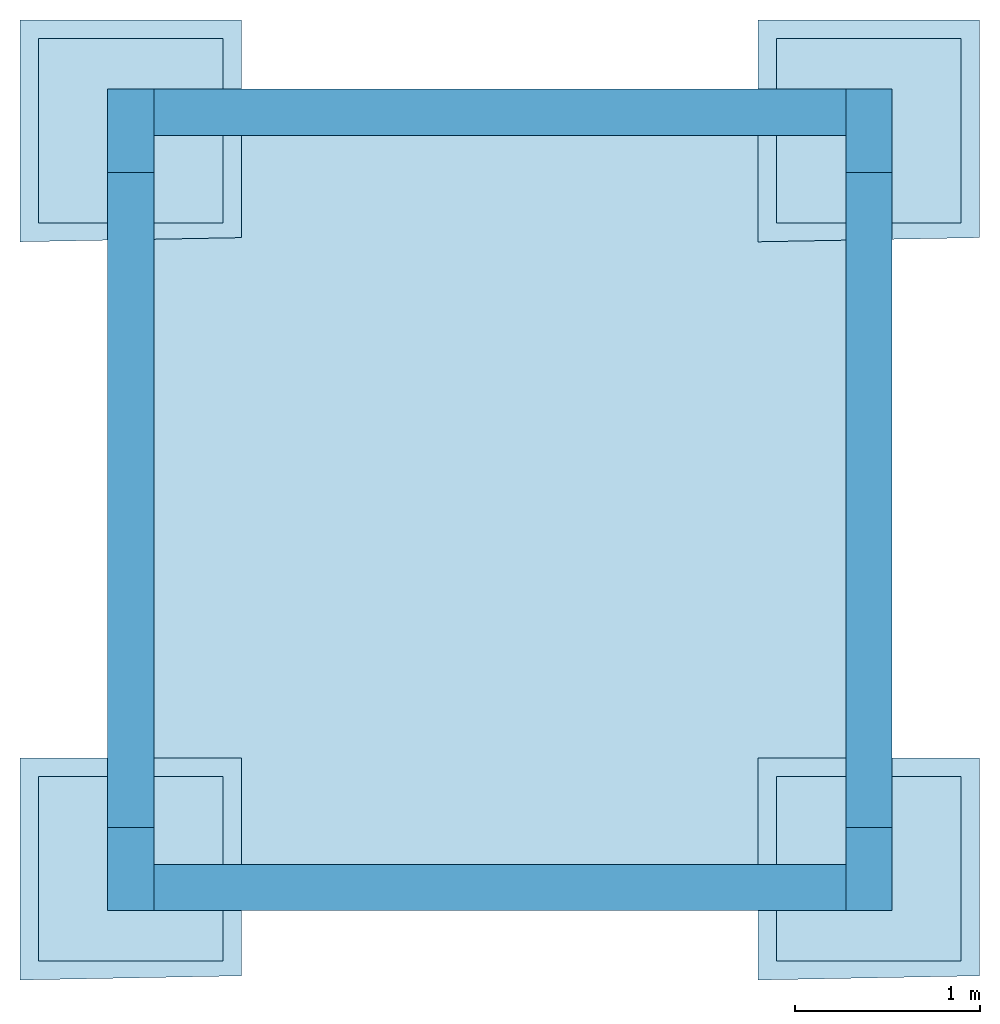
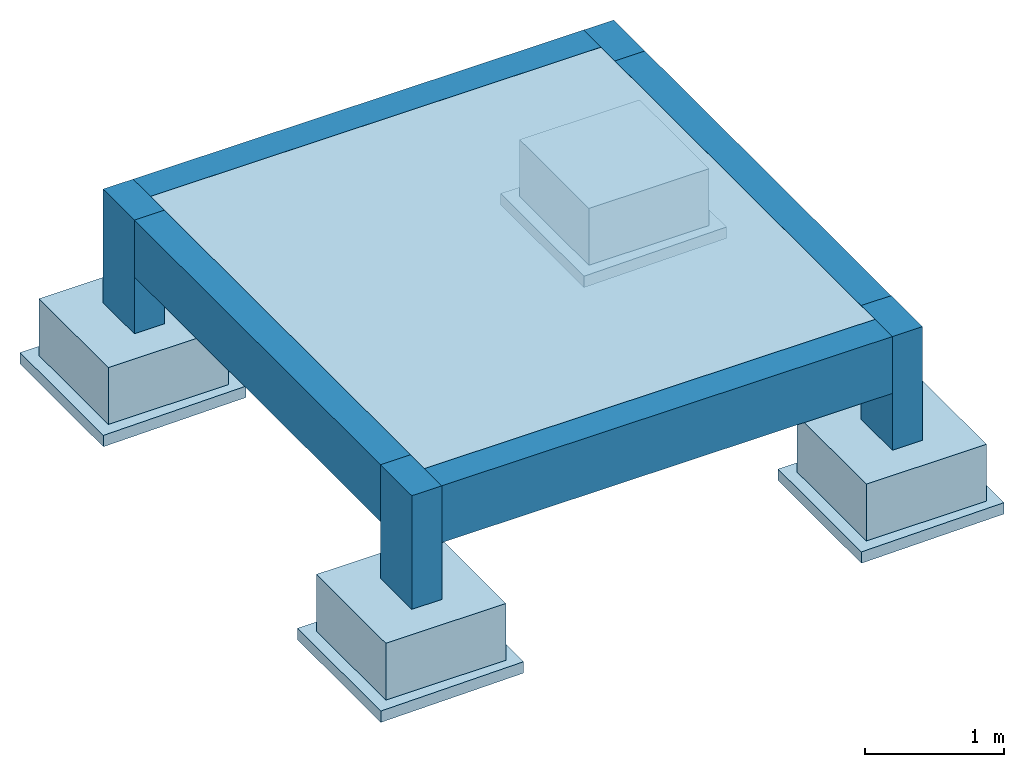
# One storey: 5 slabs, 4 beams, 4 columns, 4 footings.
"""IFC4X3_ADD2 building model written with IfcOpenShell, lengths in metres."""

from ifc_helpers import new_model, entity, si_unit, converted_unit, frame, origin_with_axes, origin_2d_with_axis, place, context, subcontext, project, spatial, indexed_curve, rectangle, outline, extrude, material, layer, layer_set, layer_usage, material_profile, profile_set, profile_usage, type_object, element, save


model = new_model("IFC4X3_ADD2")

# Units and contexts
model_context = context("Model", 3, precision=1e-05, world=origin_with_axes())
plan_context = context("Plan", 2, precision=1e-05, world=origin_2d_with_axis())
body_context = subcontext(model_context, "Body", "Model", "MODEL_VIEW")
ifc_project = project(units=[si_unit("VOLUMEUNIT", "CUBIC_METRE"), si_unit("LENGTHUNIT", "METRE"), converted_unit("PLANEANGLEUNIT", "degree", entity("IfcReal", 0.0174532925199433), si_unit("PLANEANGLEUNIT", "RADIAN"), dimensions=[0, 0, 0, 0, 0, 0, 0]), si_unit("AREAUNIT", "SQUARE_METRE")], contexts=[model_context, plan_context])

# Site, building, storey
site_placement = place(None, origin_with_axes())
site = spatial("IfcSite", under=ifc_project, at=site_placement)
building_placement = place(site_placement, origin_with_axes())
building = spatial("IfcBuilding", under=site, at=building_placement, Name="Building")
storey_placement = place(building_placement, frame((0.0, 0.0, -1.0), z_axis=(0.0, 0.0, 1.0), x_axis=(1.0, 0.0, 0.0)))
storey = spatial("IfcBuildingStorey", under=building, at=storey_placement, Name="F1")

# Footings
ifc_material_1 = material(Name="C25/30", Category="concrete")
ifc_layer_1 = layer(ifc_material_1, 0.5)
ifc_layer_set_1 = layer_set([ifc_layer_1])
ifc_layer_usage_1 = layer_usage(ifc_layer_set_1, "AXIS3", "POSITIVE", -0.5)
footing_type = type_object("IfcFootingType", Name="PAD-500", PredefinedType="PAD_FOOTING", material=ifc_layer_set_1)
footing_1_placement = place(storey_placement, origin_with_axes())
element("IfcFooting", 1, at=footing_1_placement, inside=storey, type_object=footing_type, material=ifc_layer_usage_1, Name="PAD-500", context=body_context, shape_type="SweptSolid", body=[
    extrude(outline(indexed_curve([(0.0, 0.0), (7.54979012640433e-08, 1.0), (1.00000011920929, 0.999999940395355), (1.0, -5.96046447753906e-08), (0.0, 0.0)])), frame((0.0, 0.0, -0.5), z_axis=(0.0, 0.0, 1.0), x_axis=(1.0, 0.0, 0.0)), (0.0, 0.0, 1.0), 0.5),
])
ifc_layer_usage_2 = layer_usage(ifc_layer_set_1, "AXIS3", "POSITIVE", -0.5)
footing_2_placement = place(storey_placement, frame((0.0, 4.0, 0.0), z_axis=(0.0, 0.0, 1.0), x_axis=(1.0, 0.0, 0.0)))
element("IfcFooting", 2, at=footing_2_placement, inside=storey, type_object=footing_type, material=ifc_layer_usage_2, Name="PAD-500", context=body_context, shape_type="SweptSolid", body=[
    extrude(outline(indexed_curve([(0.0, 0.0), (7.54979012640433e-08, 1.0), (1.00000011920929, 0.999999940395355), (1.0, -5.96046447753906e-08), (0.0, 0.0)])), frame((0.0, 0.0, -0.5), z_axis=(0.0, 0.0, 1.0), x_axis=(1.0, 0.0, 0.0)), (0.0, 0.0, 1.0), 0.5),
])
ifc_layer_usage_3 = layer_usage(ifc_layer_set_1, "AXIS3", "POSITIVE", -0.5)
footing_3_placement = place(storey_placement, frame((4.0, 0.0, 0.0), z_axis=(0.0, 0.0, 1.0), x_axis=(1.0, 0.0, 0.0)))
element("IfcFooting", 3, at=footing_3_placement, inside=storey, type_object=footing_type, material=ifc_layer_usage_3, Name="PAD-500", context=body_context, shape_type="SweptSolid", body=[
    extrude(outline(indexed_curve([(0.0, 0.0), (7.54979012640433e-08, 1.0), (1.00000011920929, 0.999999940395355), (1.0, -5.96046447753906e-08), (0.0, 0.0)])), frame((0.0, 0.0, -0.5), z_axis=(0.0, 0.0, 1.0), x_axis=(1.0, 0.0, 0.0)), (0.0, 0.0, 1.0), 0.5),
])
ifc_layer_usage_4 = layer_usage(ifc_layer_set_1, "AXIS3", "POSITIVE", -0.5)
footing_4_placement = place(storey_placement, frame((4.0, 4.0, 0.0), z_axis=(0.0, 0.0, 1.0), x_axis=(1.0, 0.0, 0.0)))
element("IfcFooting", 4, at=footing_4_placement, inside=storey, type_object=footing_type, material=ifc_layer_usage_4, Name="PAD-500", context=body_context, shape_type="SweptSolid", body=[
    extrude(outline(indexed_curve([(0.0, 0.0), (7.54979012640433e-08, 1.0), (1.00000011920929, 0.999999940395355), (1.0, -5.96046447753906e-08), (0.0, 0.0)])), frame((0.0, 0.0, -0.5), z_axis=(0.0, 0.0, 1.0), x_axis=(1.0, 0.0, 0.0)), (0.0, 0.0, 1.0), 0.5),
])

# Columns
ifc_material_2 = material(Name="C30/37", Category="concrete")
ifc_material_profile_1 = material_profile(ifc_material_2, rectangle(XDim=0.25, YDim=0.449999988079071))
ifc_profile_set_1 = profile_set([ifc_material_profile_1])
ifc_profile_usage_1 = profile_usage(ifc_profile_set_1, cardinal=2)
column_type = type_object("IfcColumnType", Name="COL-250x450", PredefinedType="COLUMN", material=ifc_profile_set_1)
column_1_placement = place(storey_placement, frame((0.5, 0.27499994635582, 0.0), z_axis=(0.0, 0.0, 1.0), x_axis=(1.0, 0.0, 0.0)))
element("IfcColumn", 5, at=column_1_placement, inside=storey, type_object=column_type, material=ifc_profile_usage_1, Name="COL-250x450", context=body_context, shape_type="SweptSolid", body=[
    extrude(rectangle(XDim=0.25, YDim=0.449999988079071), frame((0.0, 0.224999994039536, 0.0), z_axis=(0.0, 0.0, 1.0), x_axis=(1.0, 0.0, 0.0)), (0.0, 0.0, 1.0), 1.0),
])
ifc_profile_usage_2 = profile_usage(ifc_profile_set_1, cardinal=2)
column_2_placement = place(storey_placement, frame((0.5, 4.27500009536743, 0.0), z_axis=(0.0, 0.0, 1.0), x_axis=(1.0, 0.0, 0.0)))
element("IfcColumn", 6, at=column_2_placement, inside=storey, type_object=column_type, material=ifc_profile_usage_2, Name="COL-250x450", context=body_context, shape_type="SweptSolid", body=[
    extrude(rectangle(XDim=0.25, YDim=0.449999988079071), frame((0.0, 0.224999994039536, 0.0), z_axis=(0.0, 0.0, 1.0), x_axis=(1.0, 0.0, 0.0)), (0.0, 0.0, 1.0), 1.0),
])
ifc_profile_usage_3 = profile_usage(ifc_profile_set_1, cardinal=2)
column_3_placement = place(storey_placement, frame((4.5, 0.27499994635582, 0.0), z_axis=(0.0, 0.0, 1.0), x_axis=(1.0, 0.0, 0.0)))
element("IfcColumn", 7, at=column_3_placement, inside=storey, type_object=column_type, material=ifc_profile_usage_3, Name="COL-250x450", context=body_context, shape_type="SweptSolid", body=[
    extrude(rectangle(XDim=0.25, YDim=0.449999988079071), frame((0.0, 0.224999994039536, 0.0), z_axis=(0.0, 0.0, 1.0), x_axis=(1.0, 0.0, 0.0)), (0.0, 0.0, 1.0), 1.0),
])
ifc_profile_usage_4 = profile_usage(ifc_profile_set_1, cardinal=2)
column_4_placement = place(storey_placement, frame((4.5, 4.27500009536743, 0.0), z_axis=(0.0, 0.0, 1.0), x_axis=(1.0, 0.0, 0.0)))
element("IfcColumn", 8, at=column_4_placement, inside=storey, type_object=column_type, material=ifc_profile_usage_4, Name="COL-250x450", context=body_context, shape_type="SweptSolid", body=[
    extrude(rectangle(XDim=0.25, YDim=0.449999988079071), frame((0.0, 0.224999994039536, 0.0), z_axis=(0.0, 0.0, 1.0), x_axis=(1.0, 0.0, 0.0)), (0.0, 0.0, 1.0), 1.0),
])

# Beams
ifc_material_3 = material()
ifc_material_profile_2 = material_profile(ifc_material_3, rectangle(XDim=0.25, YDim=0.5))
ifc_profile_set_2 = profile_set([ifc_material_profile_2])
ifc_profile_usage_5 = profile_usage(ifc_profile_set_2, cardinal=8)
beam_type = type_object("IfcBeamType", Name="BEM-250x500", PredefinedType="BEAM", material=ifc_profile_set_2)
beam_1_placement = place(storey_placement, frame((0.500000178813934, 0.724999904632568, 1.0), z_axis=(-8.74227765734753e-08, 0.999999999999993, 7.54979012640428e-08), x_axis=(-0.999999999999992, -8.74227765734752e-08, 8.74227836789026e-08)))
element("IfcBeam", 9, at=beam_1_placement, inside=storey, type_object=beam_type, material=ifc_profile_usage_5, Name="250x500", context=body_context, shape_type="SweptSolid", body=[
    extrude(rectangle(XDim=0.25, YDim=0.5), frame((0.0, -0.25, 0.0), z_axis=(0.0, 0.0, 1.0), x_axis=(1.0, 0.0, 0.0)), (0.0, 0.0, 1.0), 3.55000012894753),
])
ifc_profile_usage_6 = profile_usage(ifc_profile_set_2, cardinal=8)
beam_2_placement = place(storey_placement, frame((4.5, 0.724999904632568, 1.0), z_axis=(-8.74227765734753e-08, 0.999999999999993, 7.54979012640428e-08), x_axis=(-0.999999999999992, -8.74227765734752e-08, 8.74227836789026e-08)))
element("IfcBeam", 10, at=beam_2_placement, inside=storey, type_object=beam_type, material=ifc_profile_usage_6, Name="250x500", context=body_context, shape_type="SweptSolid", body=[
    extrude(rectangle(XDim=0.25, YDim=0.5), frame((0.0, -0.25, 0.0), z_axis=(0.0, 0.0, 1.0), x_axis=(1.0, 0.0, 0.0)), (0.0, 0.0, 1.0), 3.55000012894753),
])
ifc_profile_usage_7 = profile_usage(ifc_profile_set_2, cardinal=8)
beam_3_placement = place(storey_placement, frame((4.375, 4.59999990463257, 1.0), z_axis=(-0.999999999999997, -1.19248735330757e-08, 7.54979012640431e-08), x_axis=(1.1924880638503e-08, -0.999999999999996, 8.74227765734755e-08)))
element("IfcBeam", 11, at=beam_3_placement, inside=storey, type_object=beam_type, material=ifc_profile_usage_7, Name="250x500", context=body_context, shape_type="SweptSolid", body=[
    extrude(rectangle(XDim=0.25, YDim=0.5), frame((0.0, -0.25, 0.0), z_axis=(0.0, 0.0, 1.0), x_axis=(1.0, 0.0, 0.0)), (0.0, 0.0, 1.0), 3.75000025431315),
])
ifc_profile_usage_8 = profile_usage(ifc_profile_set_2, cardinal=8)
beam_4_placement = place(storey_placement, frame((4.375, 0.400000095367432, 1.0), z_axis=(-0.999999999999997, -1.19248735330757e-08, 7.54979012640431e-08), x_axis=(1.1924880638503e-08, -0.999999999999996, 8.74227765734755e-08)))
element("IfcBeam", 12, at=beam_4_placement, inside=storey, type_object=beam_type, material=ifc_profile_usage_8, Name="250x500", context=body_context, shape_type="SweptSolid", body=[
    extrude(rectangle(XDim=0.25, YDim=0.5), frame((0.0, -0.25, 0.0), z_axis=(0.0, 0.0, 1.0), x_axis=(1.0, 0.0, 0.0)), (0.0, 0.0, 1.0), 3.75000025431315),
])

# Slabs
ifc_layer_2 = layer(ifc_material_1, 0.200000002980232)
ifc_layer_set_2 = layer_set([ifc_layer_2])
ifc_layer_usage_5 = layer_usage(ifc_layer_set_2, "AXIS3", "POSITIVE", -0.200000002980232)
slab_type_1 = type_object("IfcSlabType", Name="SLB-200", PredefinedType="BASESLAB", material=ifc_layer_set_2)
slab_1_placement = place(storey_placement, frame((0.624999761581421, 0.525000035762787, 1.0), z_axis=(0.0, 0.0, 1.0), x_axis=(1.0, 0.0, 0.0)))
element("IfcSlab", 13, at=slab_1_placement, inside=storey, type_object=slab_type_1, material=ifc_layer_usage_5, Name="200", context=body_context, shape_type="SweptSolid", body=[
    extrude(outline(indexed_curve([(0.0, 0.0), (0.0, 3.94999980926514), (3.75000023841858, 3.94999980926514), (3.74999976158142, -3.66568565368652e-05), (0.0, 0.0)])), frame((0.0, 0.0, -0.200000002980232), z_axis=(0.0, 0.0, 1.0), x_axis=(1.0, 0.0, 0.0)), (0.0, 0.0, 1.0), 0.200000002980232),
])
ifc_material_4 = material(Name="C12/15", Category="concrete")
ifc_layer_3 = layer(ifc_material_4, 0.100000001490116)
ifc_layer_set_3 = layer_set([ifc_layer_3])
ifc_layer_usage_6 = layer_usage(ifc_layer_set_3, "AXIS3", "POSITIVE", -0.100000001490116)
slab_type_2 = type_object("IfcSlabType", Name="BLN-100", PredefinedType="BASESLAB", material=ifc_layer_set_3)
slab_2_placement = place(storey_placement, frame((0.0865432024002075, 5.0, -0.5), z_axis=(0.0, 0.0, 1.0), x_axis=(1.0, 0.0, 0.0)))
element("IfcSlab", 14, at=slab_2_placement, inside=storey, type_object=slab_type_2, material=ifc_layer_usage_6, Name="100", context=body_context, shape_type="SweptSolid", body=[
    extrude(outline(indexed_curve([(-0.186543226242065, -1.10190343856812), (1.01345682144165, -1.07927513122559), (1.01345694065094, 0.0999999940395355), (-0.186543107032776, 0.100000001490116), (-0.186543226242065, -1.10190343856812)])), frame((0.0, 0.0, -0.100000001490116), z_axis=(0.0, 0.0, 1.0), x_axis=(1.0, 0.0, 0.0)), (0.0, 0.0, 1.0), 0.100000001490116),
])
ifc_layer_usage_7 = layer_usage(ifc_layer_set_3, "AXIS3", "POSITIVE", -0.100000001490116)
slab_3_placement = place(storey_placement, frame((0.0865432024002075, 1.0, -0.5), z_axis=(0.0, 0.0, 1.0), x_axis=(1.0, 0.0, 0.0)))
element("IfcSlab", 15, at=slab_3_placement, inside=storey, type_object=slab_type_2, material=ifc_layer_usage_7, Name="100", context=body_context, shape_type="SweptSolid", body=[
    extrude(outline(indexed_curve([(-0.186543226242065, -1.10190343856812), (1.01345682144165, -1.07927513122559), (1.01345694065094, 0.0999999940395355), (-0.186543107032776, 0.100000001490116), (-0.186543226242065, -1.10190343856812)])), frame((0.0, 0.0, -0.100000001490116), z_axis=(0.0, 0.0, 1.0), x_axis=(1.0, 0.0, 0.0)), (0.0, 0.0, 1.0), 0.100000001490116),
])
ifc_layer_usage_8 = layer_usage(ifc_layer_set_3, "AXIS3", "POSITIVE", -0.100000001490116)
slab_4_placement = place(storey_placement, frame((4.08654308319092, 5.0, -0.5), z_axis=(0.0, 0.0, 1.0), x_axis=(1.0, 0.0, 0.0)))
element("IfcSlab", 16, at=slab_4_placement, inside=storey, type_object=slab_type_2, material=ifc_layer_usage_8, Name="100", context=body_context, shape_type="SweptSolid", body=[
    extrude(outline(indexed_curve([(-0.186543226242065, -1.10190343856812), (1.01345682144165, -1.07927513122559), (1.01345694065094, 0.0999999940395355), (-0.186543107032776, 0.100000001490116), (-0.186543226242065, -1.10190343856812)])), frame((0.0, 0.0, -0.100000001490116), z_axis=(0.0, 0.0, 1.0), x_axis=(1.0, 0.0, 0.0)), (0.0, 0.0, 1.0), 0.100000001490116),
])
ifc_layer_usage_9 = layer_usage(ifc_layer_set_3, "AXIS3", "POSITIVE", -0.100000001490116)
slab_5_placement = place(storey_placement, frame((4.08654308319092, 1.0, -0.5), z_axis=(0.0, 0.0, 1.0), x_axis=(1.0, 0.0, 0.0)))
element("IfcSlab", 17, at=slab_5_placement, inside=storey, type_object=slab_type_2, material=ifc_layer_usage_9, Name="100", context=body_context, shape_type="SweptSolid", body=[
    extrude(outline(indexed_curve([(-0.186543226242065, -1.10190343856812), (1.01345682144165, -1.07927513122559), (1.01345694065094, 0.0999999940395355), (-0.186543107032776, 0.100000001490116), (-0.186543226242065, -1.10190343856812)])), frame((0.0, 0.0, -0.100000001490116), z_axis=(0.0, 0.0, 1.0), x_axis=(1.0, 0.0, 0.0)), (0.0, 0.0, 1.0), 0.100000001490116),
])

save(model, "model.ifc")
